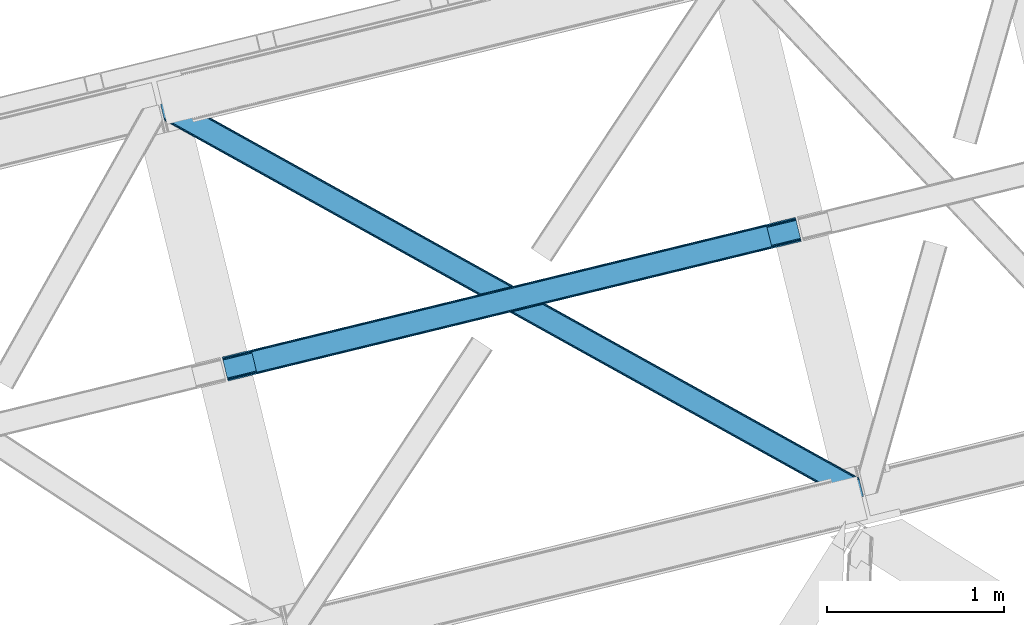
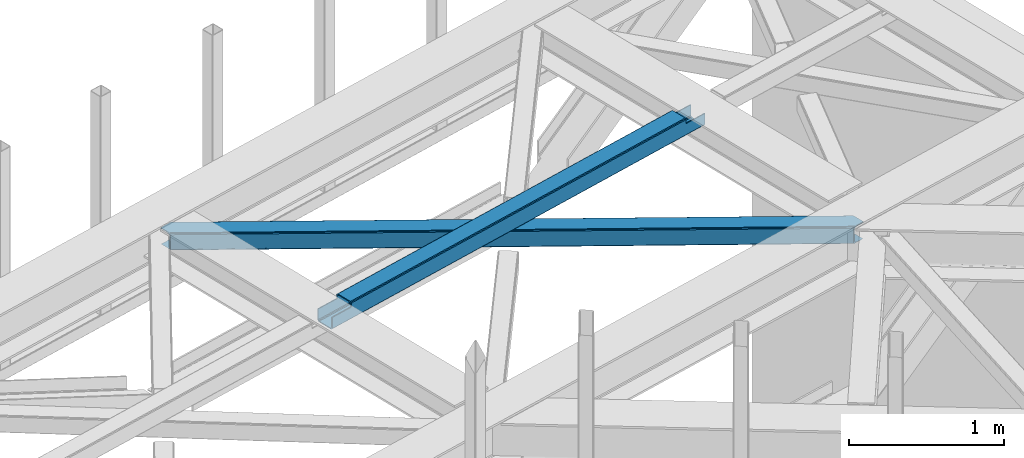
# One storey, part 59 of 67: 1 beam, 1 member.
"""IFC4 building model written with IfcOpenShell, lengths in millimetres."""

from ifc_helpers import new_model, entity, si_unit, converted_unit, derived_unit, direction, frame, origin, place, context, subcontext, project, spatial, triangles, polygons, material, type_object, element, save


model = new_model("IFC4")

# Units and contexts
model_context = context("Model", 3, precision=0.01, world=origin(), true_north=direction((6.12303176911189e-17, 1.0)))
plan_context = context("Plan", 3, precision=0.01, world=origin(), true_north=direction((6.12303176911189e-17, 1.0)))
body_context = subcontext(model_context, "Body", "Model", "MODEL_VIEW")
ifc_project = project(units=[si_unit("LENGTHUNIT", "METRE", prefix="MILLI"), si_unit("AREAUNIT", "SQUARE_METRE"), si_unit("VOLUMEUNIT", "CUBIC_METRE"), converted_unit("PLANEANGLEUNIT", "DEGREE", entity("IfcRatioMeasure", 0.0174532925199433), si_unit("PLANEANGLEUNIT", "RADIAN"), dimensions=[0, 0, 0, 0, 0, 0, 0]), si_unit("MASSUNIT", "GRAM", prefix="KILO"), derived_unit("MASSDENSITYUNIT", [(si_unit("MASSUNIT", "GRAM", prefix="KILO"), 1), (si_unit("LENGTHUNIT", "METRE"), -3)]), derived_unit("MOMENTOFINERTIAUNIT", [(si_unit("LENGTHUNIT", "METRE"), 4)]), si_unit("TIMEUNIT", "SECOND"), si_unit("FREQUENCYUNIT", "HERTZ"), si_unit("THERMODYNAMICTEMPERATUREUNIT", "DEGREE_CELSIUS"), derived_unit("THERMALTRANSMITTANCEUNIT", [(si_unit("MASSUNIT", "GRAM", prefix="KILO"), 1), (si_unit("THERMODYNAMICTEMPERATUREUNIT", "KELVIN"), -1), (si_unit("TIMEUNIT", "SECOND"), -3)]), derived_unit("VOLUMETRICFLOWRATEUNIT", [(si_unit("LENGTHUNIT", "METRE"), 3), (si_unit("TIMEUNIT", "SECOND"), -1)]), derived_unit("MASSFLOWRATEUNIT", [(si_unit("MASSUNIT", "GRAM", prefix="KILO"), 1), (si_unit("TIMEUNIT", "SECOND"), -1)]), derived_unit("ROTATIONALFREQUENCYUNIT", [(si_unit("TIMEUNIT", "SECOND"), -1)]), si_unit("ELECTRICCURRENTUNIT", "AMPERE"), si_unit("ELECTRICVOLTAGEUNIT", "VOLT"), si_unit("POWERUNIT", "WATT"), si_unit("FORCEUNIT", "NEWTON", prefix="KILO"), si_unit("ILLUMINANCEUNIT", "LUX"), si_unit("LUMINOUSFLUXUNIT", "LUMEN"), si_unit("LUMINOUSINTENSITYUNIT", "CANDELA"), derived_unit("USERDEFINED", [(si_unit("MASSUNIT", "GRAM", prefix="KILO"), -1), (si_unit("LENGTHUNIT", "METRE"), -2), (si_unit("TIMEUNIT", "SECOND"), 3), (si_unit("LUMINOUSFLUXUNIT", "LUMEN"), 1)]), derived_unit("LINEARVELOCITYUNIT", [(si_unit("LENGTHUNIT", "METRE"), 1), (si_unit("TIMEUNIT", "SECOND"), -1)]), si_unit("PRESSUREUNIT", "PASCAL"), derived_unit("USERDEFINED", [(si_unit("LENGTHUNIT", "METRE"), -2), (si_unit("MASSUNIT", "GRAM", prefix="KILO"), 1), (si_unit("TIMEUNIT", "SECOND"), -2)]), derived_unit("LINEARFORCEUNIT", [(si_unit("MASSUNIT", "GRAM", prefix="KILO"), 1), (si_unit("LENGTHUNIT", "METRE"), 1), (si_unit("TIMEUNIT", "SECOND"), -2), (si_unit("LENGTHUNIT", "METRE"), -1)]), derived_unit("PLANARFORCEUNIT", [(si_unit("MASSUNIT", "GRAM", prefix="KILO"), 1), (si_unit("LENGTHUNIT", "METRE"), 1), (si_unit("TIMEUNIT", "SECOND"), -2), (si_unit("LENGTHUNIT", "METRE"), -2)])], contexts=[model_context, plan_context])

# Site, building, storey
site_placement = place(None, origin())
site = spatial("IfcSite", under=ifc_project, at=site_placement, CompositionType="ELEMENT")
building_placement = place(site_placement, origin())
building = spatial("IfcBuilding", under=site, at=building_placement, CompositionType="ELEMENT")
storey_placement = place(building_placement, frame((0.0, 0.0, 19800.0)))
storey = spatial("IfcBuildingStorey", under=building, at=storey_placement, CompositionType="ELEMENT", Elevation=19800.0)

# Beam
ifc_material = material(Name="Metal painted (White)")
beam_type = type_object("IfcBeamType", PredefinedType="BEAM")
beam_placement = place(storey_placement, frame((-5791.52662095233, 17728.1965813642, 3967.02022389142)))
element("IfcBeam", 1, at=beam_placement, inside=storey, type_object=beam_type, material=ifc_material, ObjectType="Steel Beam", PredefinedType="BEAM", context=body_context, shape_type="Tessellation", body=[
    polygons([(31.1823923917744, 8.09507685196108, 17.8030399336114), (31.4978703677328, 6.80086440699434, 24.4999999999988), (3264.82311986252, 794.958101878828, 24.4999999999988), (3264.50764188657, 796.252314323799, 17.8030399336114), (30.2839871259208, 11.7806820741907, 12.1256313292298), (3263.60923662071, 799.937919546027, 12.1256313292298), (28.9394286278375, 17.2965800886775, 8.33210818105214), (3262.26467812263, 805.453817560513, 8.33210818105214), (27.3534137404024, 23.8030254244704, 7.00000000000274), (3260.6786632352, 811.960262896304, 7.00000000000274), (4.21622439084668, 118.720708051134, 8.33210818105214), (5.80223927828181, 112.214262715345, 7.00000000000274), (3239.12748877308, 900.371500187181, 7.00000000000274), (3237.54147388564, 906.877945522969, 8.33210818105214), (2.87166589276448, 124.236606065622, 12.1256313292342), (3236.19691538756, 912.393843537458, 12.1256313292342), (1.97326062691085, 127.92221128785, 17.8030399336114), (3235.29851012171, 916.079448759688, 17.8030399336114), (1.65778265095034, 129.216423732821, 24.4999999999988), (3234.98303214574, 917.373661204657, 24.4999999999988), (33.1556530186647, 4.33146851719357e-12, 17.5000000000004), (33.1556530186593, 4.33146851719357e-12, 99.499999999999), (31.4978703677263, 6.80086440699434, 99.499999999999), (1.65778265094385, 129.216423732821, 99.499999999999), (1.08286712929839e-11, 136.017288139811, 99.499999999999), (1.73258740687743e-11, 136.017288139811, 17.5000000000004), (0.315477975975662, 134.723075694842, 10.803039933613), (1.2138832418293, 131.037470472615, 5.12563132923143), (2.55844173991258, 125.521572458126, 1.33210818105373), (4.14445662734879, 119.015127122335, 0.0), (29.0111963913332, 17.0021610174804, 0.0), (30.5972112787684, 10.4957156816918, 1.33210818105373), (31.9417697768527, 4.97981766719851, 5.12563132923576), (32.8401750427042, 1.29421244497324, 10.803039933613), (3233.3252494948, 924.174525611642, 17.5000000000004), (3233.3252494948, 924.174525611642, 99.499999999999), (3234.98303214573, 917.373661204653, 99.499999999999), (3264.82311986251, 794.958101878828, 99.499999999999), (3266.48090251344, 788.157237471836, 99.499999999999), (3266.48090251345, 788.157237471836, 17.5000000000004), (3266.16542453748, 789.451449916805, 10.803039933613), (3265.26701927163, 793.137055139028, 5.12563132923576), (3263.92246077355, 798.652953153521, 1.33210818105373), (3262.33644588611, 805.159398489312, 0.0), (3237.46970612213, 907.172364594166, 0.0), (3235.88369123469, 913.678809929959, 1.33210818105373), (3234.53913273661, 919.194707944448, 5.12563132923143), (3233.64072747076, 922.880313166674, 10.803039933613), (3100.63931227489, 754.936562279147, 115.5000123926), (3100.69568035975, 754.950301497761, 100.117303289864), (3101.60237409476, 755.171318256453, 99.499999999999), (194.718606580801, 46.5876811586757, 99.5063429816656), (195.631369831914, 46.8101414945052, 100.117301735448), (195.69016819363, 46.8244741223568, 115.5), (3103.26015674569, 748.370453849465, 99.499999999999), (3102.35359665345, 748.149469675956, 100.117303484932), (3102.29401388578, 748.134946643616, 122.500007895425), (197.345360928053, 40.0229783796045, 122.500002534479), (197.338587096741, 40.02132714415, 100.500009163303), (196.748205195732, 39.8773799905087, 99.5697919021647), (3071.76229593267, 877.586844452971, 99.5063429816656), (3070.85318707321, 877.365274290259, 100.117299778624), (3070.79681898834, 877.351535071645, 115.50000888136), (165.850080476849, 169.240033448186, 115.5), (165.840462203343, 169.237688832044, 100.50000941238), (165.250325295043, 169.093836777333, 99.5761204674868), (3069.73269731775, 884.297145621142, 99.5697919021647), (163.220745767774, 175.804071762186, 99.499999999999), (164.133244938515, 176.026503182399, 100.117301984524), (164.189439987631, 176.040201208968, 122.500002796667), (3069.13568801183, 884.151583079726, 122.500003994045), (3069.14579130066, 884.154046494295, 100.500018741102), (3069.44780216622, 882.856550457563, 129.196959150505), (3070.34113769181, 879.169709115871, 134.874360354937), (3071.68242869587, 873.653014411064, 138.667878733795), (3073.26747578188, 867.146333102988, 139.999985502214), (3098.13822482881, 765.134344553678, 139.999991354279), (3099.7257189464, 758.628259888273, 138.667885332354), (3101.07397850683, 753.113264278044, 134.874367586349), (3101.97774321404, 749.428965811092, 129.196966804773), (3100.3261226432, 756.231332675164, 122.196975799125), (3099.42235793599, 759.915631142118, 127.874376580702), (3098.07409837555, 765.430626752348, 131.667894326702), (3096.48660425796, 771.936711417748, 133.000000348631), (3074.93195508396, 860.347101493819, 132.999995276841), (3073.34690799795, 866.853782801896, 131.667888508414), (3072.00561699389, 872.370477506699, 127.874370129564), (3071.1122814683, 876.057318848393, 122.196968925133), (164.878528418712, 169.003207355194, 99.499999999999), (193.131726453735, 57.3201898040421, 131.667891818946), (191.5457115663, 63.8266351398329, 133.0), (194.476284951819, 51.8042917895531, 127.874368670764), (195.374690217671, 48.1186865673279, 122.196960066391), (169.994537104179, 152.237872430709, 133.0), (166.165558452807, 167.945821003217, 122.196960066391), (167.06396371866, 164.260215780994, 127.874368670764), (168.408522216743, 158.7443177665, 131.667891818946), (197.031411944069, 41.3175635421159, 129.196961104604), (196.136488323061, 45.0040174739024, 134.874366301861), (194.794244157311, 50.5204796458751, 138.667887185257), (193.20902395358, 57.0271186992015, 139.999994588639), (168.341882306938, 159.039986838392, 139.999994981919), (166.755021471188, 165.546225960034, 138.667887628704), (165.408105180731, 171.06154922293, 134.874366787843), (164.506189230964, 174.746298656831, 129.196961619)], [[[1, 2, 3, 4]], [[5, 1, 4, 6]], [[7, 5, 6, 8]], [[9, 7, 8, 10]], [[11, 12, 13, 14]], [[15, 11, 14, 16]], [[17, 15, 16, 18]], [[19, 17, 18, 20]], [[12, 9, 10, 13]], [[21, 22, 23, 2, 1, 5, 7, 9, 12, 11, 15, 17, 19, 24, 25, 26, 27, 28, 29, 30, 31, 32, 33, 34]], [[35, 36, 37, 20, 18, 16, 14, 13, 10, 8, 6, 4, 3, 38, 39, 40, 41, 42, 43, 44, 45, 46, 47, 48]], [[49, 50, 51, 38, 3, 2, 23, 52, 53, 54]], [[55, 39, 38, 51]], [[39, 55, 56, 57, 58, 59, 60, 22, 21, 40]], [[32, 31, 44, 43]], [[33, 32, 43, 42]], [[34, 33, 42, 41]], [[21, 34, 41, 40]], [[31, 30, 45, 44]], [[27, 26, 35, 48]], [[28, 27, 48, 47]], [[29, 28, 47, 46]], [[30, 29, 46, 45]], [[20, 37, 61, 62, 63, 64, 65, 66, 24, 19]], [[67, 36, 35, 26, 25, 68, 69, 70, 71, 72]], [[36, 67, 61, 37]], [[72, 71, 73, 74, 75, 76, 77, 78, 79, 80, 57, 56, 50, 49, 81, 82, 83, 84, 85, 86, 87, 88, 63, 62]], [[60, 52, 23, 22]], [[25, 24, 89, 68]], [[90, 91, 84, 83]], [[92, 90, 83, 82]], [[93, 92, 82, 81]], [[54, 93, 81, 49]], [[94, 85, 84, 91]], [[95, 64, 63, 88]], [[96, 95, 88, 87]], [[97, 96, 87, 86]], [[94, 97, 86, 85]], [[65, 64, 95, 96, 97, 94, 91, 90, 92, 93, 54, 53, 59, 58, 98, 99, 100, 101, 102, 103, 104, 105, 70, 69]], [[98, 58, 57, 80]], [[99, 98, 80, 79]], [[100, 99, 79, 78]], [[101, 100, 78, 77]], [[77, 76, 102, 101]], [[103, 102, 76, 75]], [[104, 103, 75, 74]], [[105, 104, 74, 73]], [[70, 105, 73, 71]]], closed=False),
])

# Member
member_type = type_object("IfcMemberType", PredefinedType="BRACE")
member_placement = place(storey_placement, frame((-6138.83285064697, 17057.1809417725, 3823.02086791992)))
element("IfcMember", 2, at=member_placement, inside=storey, type_object=member_type, ObjectType="Steel Horizontal Brace", PredefinedType="BRACE", context=body_context, shape_type="Tessellation", body=[
    triangles([(3944.44949684143, 102.671640014647, 139.998431396481), (3942.29003562927, 111.53040161133, 138.668280029295), (86.0110290527336, 2252.77993469238, 138.668280029295), (76.4226608276367, 2250.44286804199, 139.998431396481), (3940.45918807983, 119.041571044923, 134.873162841795), (94.1355331420891, 2254.76004638672, 134.873162841795), (3939.23600692749, 124.059869384764, 129.196765136716), (99.5665969848633, 2256.08438415527, 129.196765136716), (3938.80638198853, 125.821389770506, 122.499499511716), (101.473457336426, 2256.5494720459, 122.499499511716), (3314.35932312012, 472.552551269531, 17.4989318847656), (3938.80638198853, 125.821389770506, 17.4989318847656), (2666.27097473145, 832.413143920898, 17.4989318847656), (2018.18262634277, 1192.27257385254, 17.4989318847656), (722.001860046386, 1911.99259643555, 17.4989318847656), (101.473457336426, 2256.5494720459, 17.4989318847656), (1370.0942779541, 1552.13316650391, 17.4989318847656), (3902.06080513, 6.10660400390771, 139.998431396481), (3964.29058227539, 21.2754455566392, 139.998431396481), (16.6437515258785, 2163.53421936035, 139.998431396481), (0.0, 2231.81377258301, 139.998431396481), (3877.00986328125, 0.0, 122.499499511716), (3878.91657829285, 0.465087890625, 129.196765136716), (21.857386779785, 2142.14598999023, 129.196765136716), (22.2870117187495, 2140.38446960449, 122.499499511716), (3884.34793281555, 1.78942565917896, 134.873162841795), (20.6342056274407, 2147.16428833008, 134.873162841795), (3892.47229156494, 3.76953735351708, 138.668280029295), (18.8035034179684, 2154.67545776367, 138.668280029295), (1951.60791091919, 1069.10567321777, 17.4989318847656), (2602.63038253784, 707.617272949217, 17.4989318847656), (3253.65285415649, 346.127709960936, 17.4989318847656), (3877.00986328125, 0.0, 17.4989318847656), (1300.58543930054, 1430.59407348633, 17.4989318847656), (649.563258361816, 1792.08247375488, 17.4989318847656), (22.2870117187495, 2140.38446960449, 17.4989318847656), (19.5999664306637, 2151.40588989258, 122.19719238281), (18.3767852783203, 2156.42418823242, 127.873590087889), (20.0295913696282, 2149.64436950684, 115.49992675781), (20.0295913696282, 2149.64436950684, 24.4985046386719), (19.5999664306637, 2151.40588989258, 17.8035644531228), (18.4942199707029, 2155.94398498535, 12.4992370605469), (22.0515609741205, 2141.34952697754, 12.4992370605469), (16.5460830688471, 2163.93535766601, 131.666381835938), (14.3869125366209, 2172.7941192627, 132.998858642575), (0.0, 2231.81377258301, 132.998858642575), (3887.03192596436, 2.44287414550854, 115.49992675781), (3887.03192596436, 2.44287414550854, 24.4985046386719), (3912.08301315308, 8.54947814941261, 132.998858642575), (3902.49449958801, 6.21241149902198, 131.666381835938), (3894.36563529968, 4.23113708496021, 127.873590087889), (3888.93878631592, 2.90796203613354, 122.19719238281), (3946.70677185059, 93.411740112304, 132.998858642575), (3964.29058227539, 21.2754455566392, 132.998858642575), (66.4005981445307, 2247.99999389648, 132.998858642575), (21.5068267822262, 2161.17971191406, 8.33204956054396), (3894.36563529968, 4.23113708496021, 12.1248413085923), (3888.93878631592, 2.90796203613354, 17.8035644531228), (3902.49449958801, 6.21241149902198, 8.33204956054396), (3912.08301315308, 8.54947814941261, 6.99957275390625), (20.9359313964842, 2169.15945739746, 6.99957275390625), (29.0836898803709, 2142.05646057129, 5.49966430664063), (6.80074768066333, 2233.47181091308, 5.49966430664063), (5.34560394287109, 2233.11718139648, 6.99957275390625), (23.5985595703123, 2141.5053314209, 10.9597961425752), (94.6552688598631, 2254.88678283691, 5.49966430664063), (160.809370422363, 2218.15530395508, 5.49966430664063), (202.882965087891, 2045.55304870605, 5.49966430664063), (3941.06365699768, 116.561489868163, 115.49992675781), (3941.49328193665, 114.798806762694, 122.19719238281), (91.4560455322262, 2254.10659790039, 115.49992675781), (89.5445343017573, 2253.64151000977, 122.19719238281), (3942.71646308899, 109.780508422853, 127.873590087889), (84.1175399780268, 2252.31833496094, 127.873590087889), (3944.54731063843, 102.270501708983, 131.666381835938), (75.9889663696285, 2250.33706054687, 131.666381835938), (91.4560455322262, 2254.10659790039, 24.4985046386719), (84.1175399780268, 2252.31833496094, 12.1248413085923), (89.5445343017573, 2253.64151000977, 17.8035644531228), (99.5665969848633, 2256.08438415527, 10.8016662597656), (66.4005981445307, 2247.99999389648, 6.99957275390625), (75.9889663696285, 2250.33706054687, 8.33204956054396), (3941.06365699768, 116.561489868163, 24.4985046386719), (3939.04168739319, 124.856332397459, 12.4992370605469), (3942.59931907654, 110.261874389649, 12.4992370605469), (3941.49328193665, 114.798806762694, 17.8035644531228), (3940.15760765076, 97.0464019775391, 6.99957275390625), (3958.94512367248, 19.9731994628892, 6.99957275390625), (3939.58642158508, 105.026147460936, 8.33204956054396), (3883.82834243774, 1.66268920898438, 5.49966430664063), (3957.49012527466, 19.6185699462876, 5.49966430664063), (3878.91657829285, 0.465087890625, 10.8016662597656), (3932.0097038269, 124.149398803711, 5.49966430664063), (3937.49512481689, 124.700527954101, 10.9597961425752), (3800.28387794495, 48.0505554199226, 5.49966430664063), (3758.21042861938, 220.652810668944, 5.49966430664063), (162.329626464843, 2216.14147338867, 4.49972534179688), (166.107302856445, 2200.64358215332, 0.0), (199.965701293945, 2061.74275817871, 0.0), (163.947550964355, 2209.50234375, 1.33247680663771), (203.74395904541, 2046.24486694336, 4.49972534179688), (202.125453186035, 2052.88283386231, 1.33247680663771), (3311.87081222534, 468.07142944336, 5.12526855468604), (3313.71430435181, 471.388668823241, 10.8016662597656), (3309.11691055298, 463.107778930666, 1.33247680663771), (3757.3497253418, 219.960992431639, 4.49972534179688), (719.513058471679, 1907.51031188965, 5.12526855468604), (716.759156799316, 1902.54782409668, 1.33247680663771), (721.356550598144, 1910.82755126953, 10.8016662597656), (161.571533203125, 2217.14838867187, 4.99969482421875), (713.509355163574, 1896.69353027344, 0.0), (3758.96794052124, 213.323025512695, 1.33247680663771), (3761.12754707336, 204.463101196288, 0.0), (3305.86710891724, 457.253485107423, 0.0), (1364.84750518799, 1542.68723144531, 1.33247680663771), (1361.59770355225, 1536.83293762207, 0.0), (2012.93585357666, 1182.82780151367, 1.33247680663771), (2009.68605194092, 1176.9723449707, 0.0), (2661.02885284424, 822.968371582032, 1.33247680663771), (2657.77440032959, 817.112915039063, 0.0), (1367.60605773926, 1547.65204467774, 5.12526855468604), (2015.69440612793, 1187.79145202637, 5.12526855468604), (2663.7827545166, 827.932022094727, 5.12526855468604), (1369.44489898682, 1550.96812133789, 10.8016662597656), (2017.53324737549, 1191.10752868652, 10.8016662597656), (2665.62595596313, 831.248098754884, 10.8016662597656), (652.05147857666, 1796.56359558105, 5.12526855468604), (650.207986450195, 1793.24635620117, 10.8016662597656), (203.314334106445, 2045.39491882324, 5.42292480468677), (654.805380249023, 1801.52724609375, 1.33247680663771), (3256.14107437134, 350.609994506834, 5.12526855468604), (3258.8949760437, 355.572482299805, 1.33247680663771), (3797.14569740295, 56.7035156249985, 1.33247680663771), (3798.7639125824, 50.0643859863267, 4.49972534179688), (3254.29758224487, 347.292755126953, 10.8016662597656), (3799.52156982422, 49.0574707031265, 4.99969482421875), (3794.98609085083, 65.5622772216811, 0.0), (3262.14477767944, 361.426776123048, 0.0), (658.055181884765, 1807.38153991699, 0.0), (1301.23045806885, 1431.75795593262, 10.8016662597656), (1952.2529296875, 1070.26955566406, 10.8016662597656), (2603.27511062622, 708.781155395507, 10.8016662597656), (1303.07395019531, 1435.0751953125, 5.12526855468604), (1954.09642181396, 1073.58679504395, 5.12526855468604), (2605.11860275269, 712.098394775392, 5.12526855468604), (1305.82785186768, 1440.03884582519, 1.33247680663771), (1956.85032348633, 1078.54928283691, 1.33247680663771), (2607.87250442505, 717.060882568359, 1.33247680663771), (1309.07765350342, 1445.89313964844, 0.0), (1960.10012512207, 1084.40473937988, 0.0), (2611.12259674072, 722.915176391602, 0.0)], [[1, 2, 3], [3, 4, 1], [2, 5, 6], [6, 3, 2], [5, 7, 8], [8, 6, 5], [7, 9, 10], [10, 8, 7], [11, 9, 12], [9, 11, 13], [9, 14, 10], [14, 9, 13], [15, 16, 10], [17, 10, 14], [10, 17, 15], [18, 1, 4], [18, 19, 1], [4, 20, 18], [21, 20, 4], [22, 23, 24], [24, 25, 22], [23, 26, 27], [27, 24, 23], [26, 28, 29], [29, 27, 26], [28, 18, 20], [20, 29, 28], [30, 22, 25], [22, 31, 32], [30, 31, 22], [32, 33, 22], [34, 25, 35], [25, 34, 30], [36, 35, 25], [37, 27, 38], [39, 40, 25], [24, 37, 25], [37, 24, 27], [37, 39, 25], [40, 36, 25], [41, 42, 43], [43, 36, 41], [40, 41, 36], [44, 29, 20], [21, 45, 20], [46, 45, 21], [44, 38, 29], [29, 38, 27], [45, 44, 20], [47, 48, 39], [40, 39, 48], [49, 50, 45], [44, 45, 50], [50, 51, 44], [38, 44, 51], [51, 52, 38], [37, 38, 52], [52, 47, 37], [39, 37, 47], [53, 49, 45], [49, 53, 54], [45, 55, 53], [46, 55, 45], [56, 42, 57], [42, 41, 58], [48, 58, 41], [41, 40, 48], [58, 57, 42], [57, 59, 56], [59, 60, 61], [61, 56, 59], [62, 61, 63], [61, 62, 56], [64, 63, 61], [42, 56, 62], [65, 43, 42], [65, 42, 62], [62, 66, 67], [66, 62, 63], [67, 68, 62], [69, 70, 71], [72, 71, 70], [70, 73, 72], [74, 72, 73], [73, 75, 74], [76, 74, 75], [75, 53, 76], [55, 76, 53], [74, 76, 3], [6, 74, 3], [72, 6, 8], [72, 10, 71], [6, 72, 74], [10, 72, 8], [76, 4, 3], [21, 55, 46], [21, 4, 55], [76, 55, 4], [10, 77, 71], [66, 78, 79], [79, 77, 16], [16, 77, 10], [79, 80, 66], [80, 79, 16], [63, 81, 66], [81, 82, 66], [82, 78, 66], [63, 64, 81], [83, 69, 77], [71, 77, 69], [73, 5, 70], [75, 53, 1], [53, 19, 1], [53, 54, 19], [2, 75, 1], [73, 2, 5], [73, 75, 2], [9, 83, 69], [7, 70, 5], [69, 70, 9], [70, 7, 9], [12, 83, 9], [84, 85, 86], [86, 83, 12], [12, 84, 86], [60, 87, 61], [60, 88, 87], [81, 61, 87], [64, 61, 81], [85, 86, 79], [89, 85, 78], [87, 89, 82], [82, 81, 87], [78, 82, 89], [79, 78, 85], [86, 83, 77], [77, 79, 86], [28, 18, 50], [19, 49, 18], [49, 19, 54], [49, 50, 18], [51, 28, 50], [51, 26, 28], [26, 52, 23], [52, 26, 51], [22, 52, 47], [52, 22, 23], [60, 90, 59], [58, 57, 90], [57, 59, 90], [60, 91, 90], [91, 60, 88], [48, 58, 33], [92, 33, 58], [22, 48, 33], [48, 22, 47], [58, 90, 92], [85, 93, 94], [89, 93, 85], [94, 84, 85], [88, 91, 87], [87, 93, 89], [93, 87, 91], [95, 93, 90], [95, 96, 93], [93, 91, 90], [97, 98, 99], [98, 97, 100], [99, 101, 97], [101, 99, 102], [11, 84, 94], [11, 12, 84], [96, 103, 104], [94, 93, 96], [96, 104, 94], [105, 103, 106], [107, 108, 100], [100, 97, 107], [109, 107, 110], [15, 109, 16], [80, 16, 109], [109, 67, 80], [66, 80, 67], [97, 110, 107], [108, 111, 98], [98, 100, 108], [112, 113, 114], [114, 105, 112], [106, 112, 105], [94, 104, 11], [115, 116, 111], [111, 108, 115], [117, 118, 116], [116, 115, 117], [119, 120, 118], [118, 117, 119], [105, 114, 120], [120, 119, 105], [121, 115, 107], [108, 107, 115], [122, 117, 121], [115, 121, 117], [123, 119, 122], [117, 122, 119], [103, 105, 123], [119, 123, 105], [124, 121, 107], [107, 109, 124], [125, 122, 121], [121, 124, 125], [126, 123, 125], [122, 125, 123], [104, 103, 126], [123, 126, 103], [17, 124, 15], [109, 15, 124], [14, 125, 17], [124, 17, 125], [13, 126, 125], [125, 14, 13], [11, 104, 126], [126, 13, 11], [35, 43, 65], [35, 36, 43], [127, 128, 129], [65, 62, 68], [68, 128, 65], [130, 127, 101], [131, 132, 133], [133, 134, 131], [135, 131, 136], [90, 92, 95], [135, 95, 92], [134, 136, 131], [137, 133, 132], [132, 138, 137], [139, 130, 102], [102, 99, 139], [101, 102, 130], [65, 128, 35], [92, 33, 135], [32, 135, 33], [140, 34, 128], [35, 128, 34], [141, 30, 140], [34, 140, 30], [142, 31, 30], [30, 141, 142], [135, 32, 31], [31, 142, 135], [143, 140, 128], [128, 127, 143], [144, 141, 140], [140, 143, 144], [145, 142, 141], [141, 144, 145], [131, 135, 142], [142, 145, 131], [146, 143, 127], [127, 130, 146], [147, 144, 143], [143, 146, 147], [148, 145, 144], [144, 147, 148], [132, 131, 145], [145, 148, 132], [149, 146, 130], [130, 139, 149], [150, 147, 149], [146, 149, 147], [151, 148, 150], [147, 150, 148], [138, 132, 151], [148, 151, 132], [113, 137, 138], [114, 138, 151], [138, 114, 113], [120, 150, 118], [151, 120, 114], [120, 151, 150], [111, 116, 149], [150, 116, 118], [116, 150, 149], [139, 111, 149], [99, 111, 139], [98, 111, 99], [113, 106, 137], [113, 112, 106], [134, 137, 106], [134, 133, 137]]),
])

save(model, "model.ifc")
